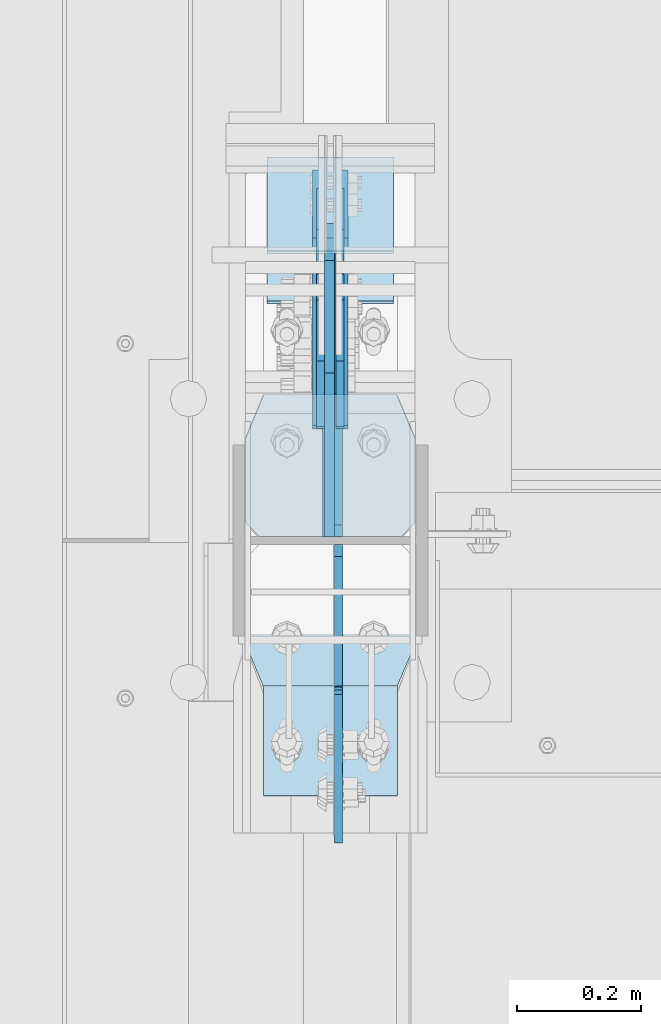
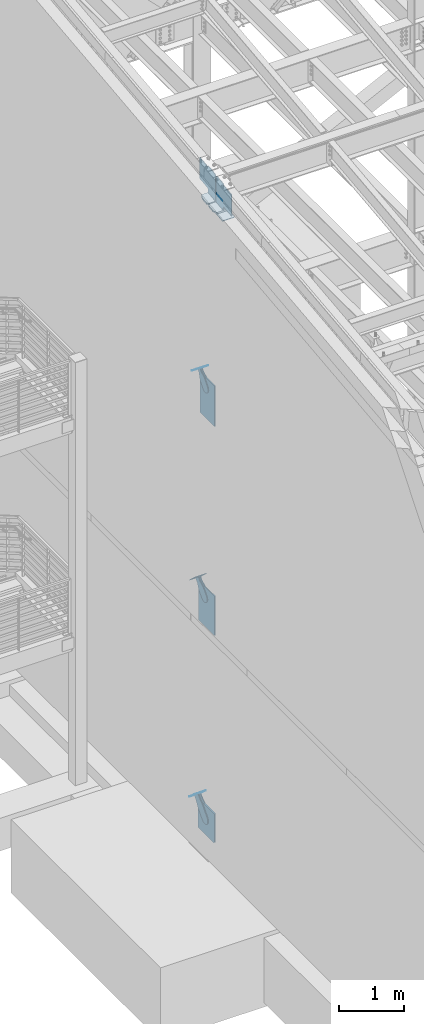
# One storey, part 1021 of 1179: 17 plates, 10 elements without a shape of their own.
"""IFC2X3 building model written with IfcOpenShell, lengths in millimetres."""

from ifc_helpers import new_model, si_unit, frame, origin_with_axes, place, context, subcontext, project, spatial, faceted_brep, material, type_object, element, aggregate, save


model = new_model("IFC2X3")

# Units and contexts
model_context = context("Model", 3, precision=1e-05, world=origin_with_axes())
body_context = subcontext(model_context, "Body", "Model", "MODEL_VIEW")
ifc_project = project(units=[si_unit("LENGTHUNIT", "METRE", prefix="MILLI"), si_unit("AREAUNIT", "SQUARE_METRE"), si_unit("VOLUMEUNIT", "CUBIC_METRE"), si_unit("MASSUNIT", "GRAM", prefix="KILO"), si_unit("TIMEUNIT", "SECOND"), si_unit("PLANEANGLEUNIT", "RADIAN"), si_unit("SOLIDANGLEUNIT", "STERADIAN"), si_unit("THERMODYNAMICTEMPERATUREUNIT", "DEGREE_CELSIUS"), si_unit("LUMINOUSINTENSITYUNIT", "LUMEN")], contexts=[model_context])

# Site, building, storey
site_placement = place(None, origin_with_axes())
site = spatial("IfcSite", under=ifc_project, at=site_placement, CompositionType="ELEMENT")
building_placement = place(site_placement, origin_with_axes())
building = spatial("IfcBuilding", under=site, at=building_placement, Name="Undefined", CompositionType="ELEMENT")
storey_placement = place(building_placement, origin_with_axes())
storey = spatial("IfcBuildingStorey", under=building, at=storey_placement, Name="Undefined", CompositionType="ELEMENT", Elevation=0.0)

# Assembly, plate
assembly_1_placement = place(storey_placement, origin_with_axes())
assembly_1 = element("IfcElementAssembly", 1, at=assembly_1_placement, inside=storey, AssemblyPlace="NOTDEFINED", PredefinedType="RIGID_FRAME")
ifc_material_1 = material(Name="STEEL/A36")
plate_type_1 = type_object("IfcPlateType", PredefinedType="NOTDEFINED")
plate_1_placement = place(assembly_1_placement, frame((415.925000000002, 27510.5287357584, 8311.01073836004), z_axis=(0.0, -0.784152810390106, 0.620567780308725), x_axis=(0.0, 0.620567780308726, 0.784152810390106)))
plate_1 = element("IfcPlate", 2, at=plate_1_placement, type_object=plate_type_1, material=ifc_material_1, context=body_context, shape_type="Brep", body=[
    faceted_brep([(0.0, -6.34999999999854, 0.0), (-101.600000000211, -6.34999999999854, -44.6881937825565), (-101.600000000211, 6.34999999999854, -44.6881937825565), (0.0, 6.34999999999854, 0.0), (-246.684985848258, -6.34999999999854, -44.6881937827675), (-246.684985848258, 6.34999999999854, -44.6881937827675), (-281.313054102191, -6.34999999999854, -37.800242748639), (-281.313054102191, 6.34999999999854, -37.800242748639), (-310.669312868691, -6.34999999999854, -18.1850177516608), (-310.669312868691, 6.34999999999854, -18.1850177516608), (-330.284537865713, -6.34999999999854, 11.1712410148393), (-330.284537865713, 6.34999999999854, 11.1712410148393), (-337.172488899912, -6.34999999999854, 45.7993031647638), (-337.172488899912, 6.34999999999854, 45.7993031647638), (-330.284537865768, -6.34999999999854, 80.4273714187839), (-330.284537865768, 6.34999999999854, 80.4273714187839), (-310.669312868773, -6.34999999999854, 109.783630185371), (-310.669312868773, 6.34999999999854, 109.783630185371), (-281.313054102271, -6.34999999999854, 129.398855182466), (-281.313054102271, 6.34999999999854, 129.398855182466), (-246.684988899762, -6.34999999999854, 136.286806216707), (-246.684988899762, 6.34999999999854, 136.286806216707), (-101.600000000377, -6.34999999999854, 136.286806216911), (-101.600000000377, 6.34999999999854, 136.286806216911), (-8.18545231595635e-11, -6.34999999999854, 91.5986124346418), (-8.18545231595635e-11, 6.34999999999854, 91.5986124346418), (67.3100000000013, -6.35000000000002, 91.5986124352912), (67.3100000000013, 6.35000000000002, 91.5986124352912), (67.309999999783, -6.35000000000002, -1.09139364212751e-11), (67.309999999783, 6.35000000000002, -1.09139364212751e-11)], [[[0, 1, 2, 3]], [[1, 4, 5, 2]], [[4, 6, 7, 5]], [[6, 8, 9, 7]], [[8, 10, 11, 9]], [[10, 12, 13, 11]], [[12, 14, 15, 13]], [[14, 16, 17, 15]], [[16, 18, 19, 17]], [[18, 20, 21, 19]], [[20, 22, 23, 21]], [[22, 24, 25, 23]], [[24, 26, 27, 25]], [[26, 28, 29, 27]], [[28, 0, 3, 29]], [[5, 7, 9, 11, 13, 15, 17, 19, 21, 23, 25, 27, 29, 3, 2]], [[28, 26, 24, 22, 20, 18, 16, 14, 12, 10, 8, 6, 4, 1, 0]]]),
])
aggregate(assembly_1, [plate_1])

assembly_2_placement = place(storey_placement, origin_with_axes())
assembly_2 = element("IfcElementAssembly", 3, at=assembly_2_placement, inside=storey, AssemblyPlace="NOTDEFINED", PredefinedType="RIGID_FRAME")
plate_2_placement = place(assembly_2_placement, frame((447.675000000002, 27510.5287357584, 8311.01073836004), z_axis=(0.0, -0.784152810390106, 0.620567780308725), x_axis=(0.0, 0.620567780308726, 0.784152810390106)))
plate_2 = element("IfcPlate", 4, at=plate_2_placement, type_object=plate_type_1, material=ifc_material_1, context=body_context, shape_type="Brep", body=[
    faceted_brep([(0.0, -6.34999999999854, 0.0), (-101.600000000211, -6.34999999999854, -44.6881937825565), (-101.600000000211, 6.34999999999854, -44.6881937825565), (0.0, 6.34999999999854, 0.0), (-246.684985848258, -6.34999999999854, -44.6881937827675), (-246.684985848258, 6.34999999999854, -44.6881937827675), (-281.313054102191, -6.34999999999854, -37.800242748639), (-281.313054102191, 6.34999999999854, -37.800242748639), (-310.669312868691, -6.34999999999854, -18.1850177516608), (-310.669312868691, 6.34999999999854, -18.1850177516608), (-330.284537865713, -6.34999999999854, 11.1712410148393), (-330.284537865713, 6.34999999999854, 11.1712410148393), (-337.172488899912, -6.34999999999854, 45.7993031647638), (-337.172488899912, 6.34999999999854, 45.7993031647638), (-330.284537865768, -6.34999999999854, 80.4273714187839), (-330.284537865768, 6.34999999999854, 80.4273714187839), (-310.669312868773, -6.34999999999854, 109.783630185371), (-310.669312868773, 6.34999999999854, 109.783630185371), (-281.313054102271, -6.34999999999854, 129.398855182466), (-281.313054102271, 6.34999999999854, 129.398855182466), (-246.684988899762, -6.34999999999854, 136.286806216707), (-246.684988899762, 6.34999999999854, 136.286806216707), (-101.600000000377, -6.34999999999854, 136.286806216911), (-101.600000000377, 6.34999999999854, 136.286806216911), (-8.18545231595635e-11, -6.34999999999854, 91.5986124346418), (-8.18545231595635e-11, 6.34999999999854, 91.5986124346418), (67.3100000000013, -6.35000000000002, 91.5986124352912), (67.3100000000013, 6.35000000000002, 91.5986124352912), (67.309999999783, -6.35000000000002, -1.09139364212751e-11), (67.309999999783, 6.35000000000002, -1.09139364212751e-11)], [[[0, 1, 2, 3]], [[1, 4, 5, 2]], [[4, 6, 7, 5]], [[6, 8, 9, 7]], [[8, 10, 11, 9]], [[10, 12, 13, 11]], [[12, 14, 15, 13]], [[14, 16, 17, 15]], [[16, 18, 19, 17]], [[18, 20, 21, 19]], [[20, 22, 23, 21]], [[22, 24, 25, 23]], [[24, 26, 27, 25]], [[26, 28, 29, 27]], [[28, 0, 3, 29]], [[5, 7, 9, 11, 13, 15, 17, 19, 21, 23, 25, 27, 29, 3, 2]], [[28, 26, 24, 22, 20, 18, 16, 14, 12, 10, 8, 6, 4, 1, 0]]]),
])
aggregate(assembly_2, [plate_2])

assembly_3_placement = place(storey_placement, origin_with_axes())
assembly_3 = element("IfcElementAssembly", 5, at=assembly_3_placement, inside=storey, Name="Plate", AssemblyPlace="NOTDEFINED", PredefinedType="RIGID_FRAME")
plate_type_2 = type_object("IfcPlateType", PredefinedType="NOTDEFINED")
plate_3_placement = place(assembly_3_placement, frame((533.400000000002, 27594.0851211982, 8326.67426617516), z_axis=(0.0, -0.784152810390106, 0.620567780308725), x_axis=(-1.0, 0.0, 0.0)))
plate_3 = element("IfcPlate", 6, at=plate_3_placement, type_object=plate_type_2, material=ifc_material_1, Name="Plate", context=body_context, shape_type="Brep", body=[
    faceted_brep([(0.0, -3.17500000000109, 0.0), (0.0, -3.17500000000291, 203.200000000368), (0.0, 3.17499999998836, 203.200000000361), (0.0, 3.17500000000109, 7.27595761418343e-12), (203.199999999997, -3.17500000000291, 203.200000000368), (203.199999999997, 3.17499999998836, 203.200000000361), (203.199999999997, -3.17499999999927, 3.63797880709171e-12), (203.199999999997, 3.17499999999382, -3.63797880709171e-12)], [[[0, 1, 2, 3]], [[1, 4, 5, 2]], [[4, 6, 7, 5]], [[6, 0, 3, 7]], [[5, 7, 3, 2]], [[6, 4, 1, 0]]]),
])
aggregate(assembly_3, [plate_3])

assembly_4_placement = place(storey_placement, origin_with_axes())
assembly_4 = element("IfcElementAssembly", 7, at=assembly_4_placement, inside=storey, Name="Plate", AssemblyPlace="NOTDEFINED", PredefinedType="RIGID_FRAME")
plate_4_placement = place(assembly_4_placement, frame((533.400000000002, 27649.6818635743, 4382.10915289887), z_axis=(0.0, -0.729241792887682, 0.684256097894611), x_axis=(-1.0, 0.0, 0.0)))
plate_4 = element("IfcPlate", 8, at=plate_4_placement, type_object=plate_type_2, material=ifc_material_1, Name="Plate", context=body_context, shape_type="Brep", body=[
    faceted_brep([(0.0, -3.17500000000109, 0.0), (0.0, -3.17500000000291, 203.200000000368), (0.0, 3.17499999998836, 203.200000000361), (0.0, 3.17500000000109, 7.27595761418343e-12), (203.199999999997, -3.17500000000291, 203.200000000368), (203.199999999997, 3.17499999998836, 203.200000000361), (203.199999999997, -3.17499999999927, 3.63797880709171e-12), (203.199999999997, 3.17499999999382, -3.63797880709171e-12)], [[[0, 1, 2, 3]], [[1, 4, 5, 2]], [[4, 6, 7, 5]], [[6, 0, 3, 7]], [[5, 7, 3, 2]], [[6, 4, 1, 0]]]),
])
aggregate(assembly_4, [plate_4])

assembly_5_placement = place(storey_placement, origin_with_axes())
assembly_5 = element("IfcElementAssembly", 9, at=assembly_5_placement, inside=storey, Name="Plate", AssemblyPlace="NOTDEFINED", PredefinedType="RIGID_FRAME")
plate_5_placement = place(assembly_5_placement, frame((533.400000000002, 27666.7905367789, 320.900120380222), z_axis=(0.0, -0.74575357167811, 0.666221892712438), x_axis=(-1.0, 0.0, 0.0)))
plate_5 = element("IfcPlate", 10, at=plate_5_placement, type_object=plate_type_2, material=ifc_material_1, Name="Plate", context=body_context, shape_type="Brep", body=[
    faceted_brep([(0.0, -3.17500000000109, 0.0), (0.0, -3.17500000000291, 203.200000000368), (0.0, 3.17499999998836, 203.200000000361), (0.0, 3.17500000000109, 7.27595761418343e-12), (203.199999999997, -3.17500000000291, 203.200000000368), (203.199999999997, 3.17499999998836, 203.200000000361), (203.199999999997, -3.17499999999927, 3.63797880709171e-12), (203.199999999997, 3.17499999999382, -3.63797880709171e-12)], [[[0, 1, 2, 3]], [[1, 4, 5, 2]], [[4, 6, 7, 5]], [[6, 0, 3, 7]], [[5, 7, 3, 2]], [[6, 4, 1, 0]]]),
])
aggregate(assembly_5, [plate_5])

# Assembly, plates
assembly_6_placement = place(storey_placement, origin_with_axes())
assembly_6 = element("IfcElementAssembly", 11, at=assembly_6_placement, inside=storey, Name="COLUMN", AssemblyPlace="NOTDEFINED", PredefinedType="RIGID_FRAME")
ifc_material_2 = material(Name="STEEL/A572-GR.50")
plate_type_3 = type_object("IfcPlateType", PredefinedType="NOTDEFINED")
plate_6_placement = place(assembly_6_placement, frame((323.850003041494, 26640.7392708403, 11698.0872863544), z_axis=(1.0, 0.0, 0.0), x_axis=(0.0, 0.993676146336441, 0.112284087038017)))
plate_6 = element("IfcPlate", 12, at=plate_6_placement, type_object=plate_type_3, material=ifc_material_2, Name="PLATE", context=body_context, shape_type="Brep", body=[
    faceted_brep([(0.0, -6.34999999999854, 0.0), (0.0, -6.350000000004, 215.899993896484), (0.0, 6.35000000000582, 215.899993896484), (0.0, 6.34999999999854, 0.0), (330.200000001782, -6.34999999994034, 215.899993896483), (330.200000001782, 6.35000000006767, 215.899993896483), (330.200000001782, -6.34999999994034, -1.47792889038101e-12), (330.200000001782, 6.35000000006767, -1.47792889038101e-12)], [[[0, 1, 2, 3]], [[1, 4, 5, 2]], [[4, 6, 7, 5]], [[6, 0, 3, 7]], [[5, 7, 3, 2]], [[6, 4, 1, 0]]]),
])
plate_type_4 = type_object("IfcPlateType", PredefinedType="NOTDEFINED")
plate_7_placement = place(assembly_6_placement, frame((295.27500000006, 26814.3139131712, 11738.3789032818), z_axis=(1.0, 0.0, 0.0), x_axis=(0.0, 0.993676146336441, 0.112284087038017)))
plate_7 = element("IfcPlate", 13, at=plate_7_placement, type_object=plate_type_4, material=ifc_material_2, Name="PLATE", context=body_context, shape_type="Brep", body=[
    faceted_brep([(207.962499617965, -14.2875000000749, 8.87325768417213e-11), (71.43750000002, -14.287499999984, 2.90469870378729e-11), (71.4375000000155, 14.2874999999949, 2.90469870378729e-11), (207.962499617975, 14.2874999999094, 8.87325768417213e-11), (230.187499999511, -14.287500000084, 22.225000381568), (230.187499999523, 14.2874999999003, 22.225000381568), (230.187500000431, -14.2875000000822, 250.824999623284), (230.187500000442, 14.2874999998985, 250.824999623284), (207.962499619063, -14.2875000000731, 273.050000004745), (207.962499619074, 14.2874999999112, 273.050000004745), (71.4375000016116, -14.2874999999858, 273.049999999798), (71.4375000016071, 14.2874999999967, 273.049999999798), (4.20737223302058, 14.2874999999931, 244.663945699182), (0.978435120117865, -14.2874999999894, 243.300616678719), (0.978435120117865, -14.2874999999894, 29.7493833255772), (4.20737223302058, 14.2874999999931, 28.3860543051127)], [[[0, 1, 2, 3]], [[4, 0, 3, 5]], [[6, 4, 5, 7]], [[8, 6, 7, 9]], [[10, 8, 9, 11]], [[10, 11, 12, 13]], [[1, 0, 4, 6, 8, 10, 13, 14]], [[2, 1, 14, 15]], [[11, 9, 7, 5, 3, 2, 15, 12]], [[14, 13, 12, 15]]]),
])
plate_type_5 = type_object("IfcPlateType", PredefinedType="NOTDEFINED")
plate_8_placement = place(assembly_6_placement, frame((568.325000000001, 27289.2635477105, 11792.0475823145), z_axis=(-1.0, 0.0, 0.0), x_axis=(0.0, -0.993676146336441, -0.112284087038017)))
plate_8 = element("IfcPlate", 14, at=plate_8_placement, type_object=plate_type_5, material=ifc_material_2, Name="PLATE", context=body_context, shape_type="Brep", body=[
    faceted_brep([(209.549999618157, -14.287499999904, 0.0), (73.0250015258425, -14.2874999999603, 0.0), (73.0250015258298, 14.2875000000258, 0.0), (209.549999618144, 14.2875000000804, 0.0), (231.774999999612, -14.2874999998949, 22.2250003814697), (231.774999999603, 14.2875000000895, 22.2250003814697), (231.774999999612, -14.2874999998949, 250.824999618533), (231.774999999603, 14.2875000000895, 250.824999618533), (209.549999618157, -14.287499999904, 273.050000000002), (209.549999618144, 14.2875000000804, 273.050000000002), (73.0250015258425, -14.2874999999603, 273.049999999998), (73.0250015258298, 14.2875000000258, 273.049999999998), (4.15974163581814, -14.2874999999876, 244.605653758279), (4.15974163581814, -14.2874999999876, 28.4443462417166), (0.930804522917242, 14.2874999999949, 29.7780376469105), (0.930804522917242, 14.2874999999949, 243.271962353085)], [[[0, 1, 2, 3]], [[4, 0, 3, 5]], [[6, 4, 5, 7]], [[8, 6, 7, 9]], [[10, 8, 9, 11]], [[1, 0, 4, 6, 8, 10, 12, 13]], [[2, 1, 13, 14]], [[11, 9, 7, 5, 3, 2, 14, 15]], [[10, 11, 15, 12]], [[14, 13, 12, 15]]]),
])
plate_type_6 = type_object("IfcPlateType", PredefinedType="NOTDEFINED")
plate_9_placement = place(assembly_6_placement, frame((445.293750000002, 27057.35, 11799.2397941051), z_axis=(0.0, 0.663574933899741, 0.748109822886957), x_axis=(0.0, 0.748109822886957, -0.663574933899741)))
plate_9 = element("IfcPlate", 15, at=plate_9_placement, type_object=plate_type_6, material=ifc_material_2, Name="PLATE", context=body_context, shape_type="Brep", body=[
    faceted_brep([(-303.238548430167, -6.35000000000002, 370.417244034568), (-303.347407870391, 6.35000000000002, 370.51520492656), (-303.447548924116, 6.35000000000002, 342.10495528072), (-303.447548924116, -6.35000000000002, 342.10495528072), (25.4641550948563, -6.35000000000002, 0.0), (0.0, -6.34999999999854, 0.0), (0.0, 6.34999999999854, 0.0), (25.4641550948563, 6.35000000000002, 0.0), (167.045917247172, -6.35000000000002, 157.353263970723), (167.045917247172, 6.35000000000002, 157.353263970723), (131.563526715495, -6.35000000000002, 197.355899250204), (131.563526715495, 6.35000000000002, 197.355899250204), (126.802866418006, -6.35000000000002, 205.238730036501), (126.802866418006, 6.35000000000002, 205.238730036501), (125.165683086001, -6.35000000000002, 214.300878700633), (125.165683086001, 6.35000000000002, 214.300878700633), (126.867175912115, -6.35000000000002, 223.351173161929), (126.867175912115, 6.35000000000002, 223.351173161929), (131.683692556814, -6.35000000000002, 231.199999512715), (131.683692556814, 6.35000000000002, 231.199999512715), (286.794657668127, -6.35000000000002, 403.589566389341), (286.794657668127, 6.35000000000002, 403.589566389341), (23.8827060644498, -6.35000000000002, 699.99493122035), (23.8827060644498, 6.35000000000002, 699.99493122035), (-127.388721232707, -6.35000000000002, 531.872607863961), (-127.388721232707, 6.35000000000002, 531.872607863961), (-134.060951024564, -6.35000000000002, 526.588932486246), (-134.060951024564, 6.35000000000002, 526.588932486246), (-142.104023886786, -6.35000000000002, 523.805974558898), (-142.104023886786, 6.35000000000002, 523.805974558898), (-150.614897093323, -6.35000000000002, 523.836193008534), (-150.614897093323, 6.35000000000002, 523.836193008534), (-158.638005243585, -6.35000000000002, 526.676195033468), (-158.638005243585, 6.35000000000002, 526.676195033468), (-161.065417892858, 6.35000000000002, 528.626645817876), (-161.065417892858, -6.35000000000002, 528.626645817876)], [[[0, 1, 2, 3]], [[4, 5, 6, 7]], [[8, 4, 7, 9]], [[10, 8, 9, 11]], [[12, 10, 11, 13]], [[14, 12, 13, 15]], [[16, 14, 15, 17]], [[18, 16, 17, 19]], [[20, 18, 19, 21]], [[22, 20, 21, 23]], [[24, 22, 23, 25]], [[26, 24, 25, 27]], [[28, 26, 27, 29]], [[30, 28, 29, 31]], [[32, 30, 31, 33]], [[32, 33, 34, 35]], [[5, 4, 8, 10, 12, 14, 16, 18, 20, 22, 24, 26, 28, 30, 32, 35, 0, 3]], [[6, 5, 3, 2]], [[34, 33, 31, 29, 27, 25, 23, 21, 19, 17, 15, 13, 11, 9, 7, 6, 2, 1]], [[35, 34, 1, 0]]]),
])
plate_type_7 = type_object("IfcPlateType", PredefinedType="NOTDEFINED")
plate_10_placement = place(assembly_6_placement, frame((445.293750000002, 27044.6499999809, 11797.4396066722), z_axis=(0.0, -0.743858433013958, 0.668337214012522), x_axis=(0.0, -0.668337214012522, -0.743858433013957)))
plate_10 = element("IfcPlate", 16, at=plate_10_placement, type_object=plate_type_7, material=ifc_material_2, Name="PLATE", context=body_context, shape_type="Brep", body=[
    faceted_brep([(-340.307722614409, -6.35000000000002, 331.196209351952), (-340.360268739241, 6.35000000000002, 331.25535654785), (-340.432897072962, 6.35000000000002, 305.869993370221), (-340.432897072962, -6.35000000000002, 305.869993370221), (28.5035613092805, -6.35000000000002, -1.04591890703887e-11), (0.0, -6.34999999999854, 0.0), (0.0, 6.34999999999854, 0.0), (28.5035613092805, 6.35000000000002, -1.04591890703887e-11), (185.535041792471, -6.35000000000002, 139.488379402524), (185.535041792471, 6.35000000000002, 139.488379402524), (150.391206739107, -6.35000000000002, 171.064189752232), (150.391206739107, 6.35000000000002, 171.064189752232), (145.102749755571, -6.35000000000002, 177.732630246504), (145.102749755571, 6.35000000000002, 177.732630246504), (142.314026896069, -6.35000000000002, 185.773706089029), (142.314026896069, 6.35000000000002, 185.773706089029), (142.338144349787, -6.35000000000002, 194.28459877081), (142.338144349787, 6.35000000000002, 194.28459877081), (145.172394309466, -6.35000000000002, 202.30974070466), (145.172394309466, 6.35000000000002, 202.30974070466), (150.498558992693, -6.35000000000002, 208.948102374491), (150.498558992693, 6.35000000000002, 208.948102374491), (319.572465694362, -6.35000000000002, 359.133576332748), (319.572465694362, 6.35000000000002, 359.133576332748), (24.8516291671876, -6.35000000000002, 623.932487042394), (24.8516291671876, 6.35000000000002, 623.932487042394), (-148.513946545472, -6.35000000000002, 469.934796538949), (-148.513946545472, 6.35000000000002, 469.934796538949), (-156.393362644572, -6.35000000000002, 465.168486686387), (-156.393362644572, 6.35000000000002, 465.168486686387), (-165.454335371476, -6.35000000000002, 463.524807607098), (-165.454335371476, 6.35000000000002, 463.524807607098), (-174.505847216309, -6.35000000000002, 465.219812325748), (-174.505847216309, 6.35000000000002, 465.219812325748), (-182.358124252696, -6.35000000000002, 470.030701330617), (-182.358124252696, 6.35000000000002, 470.030701330617), (-183.249688243475, 6.35000000000002, 470.831748115088), (-183.249688243475, -6.35000000000002, 470.831748115088)], [[[0, 1, 2, 3]], [[4, 5, 6, 7]], [[8, 4, 7, 9]], [[10, 8, 9, 11]], [[12, 10, 11, 13]], [[14, 12, 13, 15]], [[16, 14, 15, 17]], [[18, 16, 17, 19]], [[20, 18, 19, 21]], [[22, 20, 21, 23]], [[24, 22, 23, 25]], [[26, 24, 25, 27]], [[28, 26, 27, 29]], [[30, 28, 29, 31]], [[32, 30, 31, 33]], [[34, 32, 33, 35]], [[34, 35, 36, 37]], [[5, 4, 8, 10, 12, 14, 16, 18, 20, 22, 24, 26, 28, 30, 32, 34, 37, 0, 3]], [[6, 5, 3, 2]], [[36, 35, 33, 31, 29, 27, 25, 23, 21, 19, 17, 15, 13, 11, 9, 7, 6, 2, 1]], [[37, 36, 1, 0]]]),
])

# Assembly, plate
assembly_7_placement = place(storey_placement, origin_with_axes())
assembly_7 = element("IfcElementAssembly", 17, at=assembly_7_placement, inside=storey, AssemblyPlace="NOTDEFINED", PredefinedType="RIGID_FRAME")
plate_type_8 = type_object("IfcPlateType", PredefinedType="NOTDEFINED")
plate_11_placement = place(assembly_7_placement, frame((415.925000000002, 27562.1830396846, 4355.36439363649), z_axis=(0.0, -0.729241792887682, 0.684256097894611), x_axis=(0.0, 0.684256097894612, 0.729241792887681)))
plate_11 = element("IfcPlate", 18, at=plate_11_placement, type_object=plate_type_8, material=ifc_material_1, context=body_context, shape_type="Brep", body=[
    faceted_brep([(0.0, -6.34999999999854, 0.0), (-101.599999999963, -6.34999999999854, -37.5700345970108), (-101.599999999963, 6.34999999999854, -37.5700345970108), (0.0, 6.34999999999854, 0.0), (-245.369242323884, -6.34999999999854, -37.5700345970945), (-245.369242323884, 6.34999999999854, -37.5700345970945), (-281.212328723803, -6.34999999999854, -30.4404014271258), (-281.212328723803, 6.34999999999854, -30.4404014271258), (-311.598630137756, -6.34999999999854, -10.1369239370142), (-311.598630137756, 6.34999999999854, -10.1369239370142), (-331.902107627997, -6.34999999999854, 20.24937747687), (-331.902107627997, 6.34999999999854, 20.24937747687), (-339.031740798124, -6.34999999999854, 56.0924669287269), (-339.031740798124, 6.34999999999854, 56.0924669287269), (-331.902107628228, -6.34999999999854, 91.9355533287926), (-331.902107628228, 6.34999999999854, 91.9355533287926), (-311.598630138099, -6.34999999999854, 122.321854742866), (-311.598630138099, 6.34999999999854, 122.321854742866), (-281.212328724136, -6.34999999999854, 142.625332233139), (-281.212328724136, 6.34999999999854, 142.625332233139), (-245.36924079839, -6.34999999999854, 149.754965403199), (-245.36924079839, 6.34999999999854, 149.754965403199), (-101.600000000685, -6.34999999999854, 149.75496540329), (-101.600000000685, 6.34999999999854, 149.75496540329), (-4.35647962149233e-10, -6.34999999999854, 112.184930806416), (-4.35647962149233e-10, 6.34999999999854, 112.184930806416), (82.5499999996491, -6.34999999999854, 112.184930806461), (82.5499999996491, 6.34999999999854, 112.184930806461), (82.550000000203, -6.34999999999854, 1.2732925824821e-10), (82.550000000203, 6.34999999999854, 1.2732925824821e-10)], [[[0, 1, 2, 3]], [[1, 4, 5, 2]], [[4, 6, 7, 5]], [[6, 8, 9, 7]], [[8, 10, 11, 9]], [[10, 12, 13, 11]], [[12, 14, 15, 13]], [[14, 16, 17, 15]], [[16, 18, 19, 17]], [[18, 20, 21, 19]], [[20, 22, 23, 21]], [[22, 24, 25, 23]], [[24, 26, 27, 25]], [[26, 28, 29, 27]], [[28, 0, 3, 29]], [[5, 7, 9, 11, 13, 15, 17, 19, 21, 23, 25, 27, 29, 3, 2]], [[28, 26, 24, 22, 20, 18, 16, 14, 12, 10, 8, 6, 4, 1, 0]]]),
])
aggregate(assembly_7, [plate_11])

assembly_8_placement = place(storey_placement, origin_with_axes())
assembly_8 = element("IfcElementAssembly", 19, at=assembly_8_placement, inside=storey, AssemblyPlace="NOTDEFINED", PredefinedType="RIGID_FRAME")
plate_12_placement = place(assembly_8_placement, frame((447.675000000002, 27562.1830396846, 4355.36439363649), z_axis=(0.0, -0.729241792887682, 0.684256097894611), x_axis=(0.0, 0.684256097894612, 0.729241792887681)))
plate_12 = element("IfcPlate", 20, at=plate_12_placement, type_object=plate_type_8, material=ifc_material_1, context=body_context, shape_type="Brep", body=[
    faceted_brep([(0.0, -6.34999999999854, 0.0), (-101.599999999963, -6.34999999999854, -37.5700345970108), (-101.599999999963, 6.34999999999854, -37.5700345970108), (0.0, 6.34999999999854, 0.0), (-245.369242323884, -6.34999999999854, -37.5700345970945), (-245.369242323884, 6.34999999999854, -37.5700345970945), (-281.212328723803, -6.34999999999854, -30.4404014271258), (-281.212328723803, 6.34999999999854, -30.4404014271258), (-311.598630137756, -6.34999999999854, -10.1369239370142), (-311.598630137756, 6.34999999999854, -10.1369239370142), (-331.902107627997, -6.34999999999854, 20.24937747687), (-331.902107627997, 6.34999999999854, 20.24937747687), (-339.031740798124, -6.34999999999854, 56.0924669287269), (-339.031740798124, 6.34999999999854, 56.0924669287269), (-331.902107628228, -6.34999999999854, 91.9355533287926), (-331.902107628228, 6.34999999999854, 91.9355533287926), (-311.598630138099, -6.34999999999854, 122.321854742866), (-311.598630138099, 6.34999999999854, 122.321854742866), (-281.212328724136, -6.34999999999854, 142.625332233139), (-281.212328724136, 6.34999999999854, 142.625332233139), (-245.36924079839, -6.34999999999854, 149.754965403199), (-245.36924079839, 6.34999999999854, 149.754965403199), (-101.600000000685, -6.34999999999854, 149.75496540329), (-101.600000000685, 6.34999999999854, 149.75496540329), (-4.35647962149233e-10, -6.34999999999854, 112.184930806416), (-4.35647962149233e-10, 6.34999999999854, 112.184930806416), (82.5499999996491, -6.34999999999854, 112.184930806461), (82.5499999996491, 6.34999999999854, 112.184930806461), (82.550000000203, -6.34999999999854, 1.2732925824821e-10), (82.550000000203, 6.34999999999854, 1.2732925824821e-10)], [[[0, 1, 2, 3]], [[1, 4, 5, 2]], [[4, 6, 7, 5]], [[6, 8, 9, 7]], [[8, 10, 11, 9]], [[10, 12, 13, 11]], [[12, 14, 15, 13]], [[14, 16, 17, 15]], [[16, 18, 19, 17]], [[18, 20, 21, 19]], [[20, 22, 23, 21]], [[22, 24, 25, 23]], [[24, 26, 27, 25]], [[26, 28, 29, 27]], [[28, 0, 3, 29]], [[5, 7, 9, 11, 13, 15, 17, 19, 21, 23, 25, 27, 29, 3, 2]], [[28, 26, 24, 22, 20, 18, 16, 14, 12, 10, 8, 6, 4, 1, 0]]]),
])
aggregate(assembly_8, [plate_12])

# Plate
plate_type_9 = type_object("IfcPlateType", PredefinedType="NOTDEFINED")
plate_13_placement = place(assembly_6_placement, frame((431.800000000002, 27057.35, 7575.55), z_axis=(0.0, 0.0, 1.0), x_axis=(0.0, 1.0, 0.0)))
plate_13 = element("IfcPlate", 21, at=plate_13_placement, type_object=plate_type_9, material=ifc_material_2, Name="PLATE", context=body_context, shape_type="Brep", body=[
    faceted_brep([(0.0, -9.52499999999964, 0.0), (0.0, -9.52499999999998, 756.128435263005), (0.0, 9.52499999999998, 756.128435263005), (0.0, 9.52499999999964, 0.0), (263.341885783306, -9.52499999999998, 756.128435263005), (263.341885783306, 9.52499999999998, 756.128435263005), (445.088903411473, -9.52499999999998, 612.296337981949), (445.088903411473, 9.52499999999998, 612.296337981949), (445.088903411473, -9.52499999999998, 0.0), (445.088903411473, 9.52499999999998, 0.0)], [[[0, 1, 2, 3]], [[1, 4, 5, 2]], [[4, 6, 7, 5]], [[6, 8, 9, 7]], [[8, 0, 3, 9]], [[5, 7, 9, 3, 2]], [[8, 6, 4, 1, 0]]]),
])

plate_type_10 = type_object("IfcPlateType", PredefinedType="NOTDEFINED")
plate_14_placement = place(assembly_6_placement, frame((431.800000000002, 27057.3499999352, 3663.95000006083), z_axis=(0.0, 0.0, 1.0), x_axis=(0.0, 1.0, 0.0)))
plate_14 = element("IfcPlate", 22, at=plate_14_placement, type_object=plate_type_10, material=ifc_material_2, Name="PLATE", context=body_context, shape_type="Brep", body=[
    faceted_brep([(0.0, -9.52499999999964, 0.0), (0.0, -9.52499999999998, 737.174280571875), (0.0, 9.52499999999998, 737.174280571875), (0.0, 9.52499999999964, 0.0), (307.582299199603, -9.52499999999998, 737.174280571875), (307.582299199603, 9.52499999999998, 737.174280571875), (481.233001130982, -9.52499999999998, 574.235797260721), (481.233001130982, 9.52499999999998, 574.235797260721), (481.233001130982, -9.52499999999998, 0.0), (481.233001130982, 9.52499999999998, 0.0)], [[[0, 1, 2, 3]], [[1, 4, 5, 2]], [[4, 6, 7, 5]], [[6, 8, 9, 7]], [[8, 0, 3, 9]], [[5, 7, 9, 3, 2]], [[8, 6, 4, 1, 0]]]),
])

plate_type_11 = type_object("IfcPlateType", PredefinedType="NOTDEFINED")
plate_15_placement = place(assembly_6_placement, frame((431.800000000001, 27057.35, -215.9), z_axis=(0.0, 0.0, 1.0), x_axis=(0.0, 1.0, 0.0)))
plate_15 = element("IfcPlate", 23, at=plate_15_placement, type_object=plate_type_11, material=ifc_material_2, Name="PLATE", context=body_context, shape_type="Brep", body=[
    faceted_brep([(0.0, -12.7000000000007, 19.0500000000029), (0.0, -12.7, 551.799398203347), (0.0, 12.7, 551.799398203347), (0.0, 12.7000000000007, 19.0500000000029), (324.819501230952, -12.7, 551.799398203347), (324.819501230952, 12.7, 551.799398203347), (504.769838076878, -12.7, 391.040055491836), (504.769838076878, 12.7, 391.040055491836), (504.769838076878, -12.7, 0.0), (504.769838076878, 12.7, 0.0), (19.0499992370605, -12.6999999999971, 0.0), (19.0499992370605, 12.6999999999971, 0.0)], [[[0, 1, 2, 3]], [[1, 4, 5, 2]], [[4, 6, 7, 5]], [[6, 8, 9, 7]], [[8, 10, 11, 9]], [[10, 0, 3, 11]], [[5, 7, 9, 11, 3, 2]], [[10, 8, 6, 4, 1, 0]]]),
])

aggregate(assembly_6, [plate_6, plate_8, plate_9, plate_7, plate_10, plate_13, plate_14, plate_15])

# Assembly, plate
assembly_9_placement = place(storey_placement, origin_with_axes())
assembly_9 = element("IfcElementAssembly", 24, at=assembly_9_placement, inside=storey, AssemblyPlace="NOTDEFINED", PredefinedType="RIGID_FRAME")
plate_type_12 = type_object("IfcPlateType", PredefinedType="NOTDEFINED")
plate_16_placement = place(assembly_9_placement, frame((411.162500000002, 27594.6102194491, 282.352678620126), z_axis=(0.0, -0.74575357167811, 0.666221892712438), x_axis=(0.0, 0.666221892712437, 0.74575357167811)))
plate_16 = element("IfcPlate", 25, at=plate_16_placement, type_object=plate_type_12, material=ifc_material_1, context=body_context, shape_type="Brep", body=[
    faceted_brep([(0.0, -7.9375, 0.0), (-101.600000000497, -7.9375, -21.7975798445477), (-101.600000000497, 7.9375, -21.7975798445477), (0.0, 7.9375, 0.0), (-320.921138851689, -7.9375, -21.7975798443877), (-320.921138851689, 7.9375, -21.7975798443877), (-357.371735784433, -7.9375, -14.5471053160727), (-357.371735784433, 7.9375, -14.5471053160727), (-388.273059759649, -7.9375, 6.10049924760824), (-388.273059759649, 7.9375, 6.10049924760824), (-408.920664323319, -7.9375, 37.0018232228431), (-408.920664323319, 7.9375, 37.0018232228431), (-416.171138851623, -7.9375, 73.4524201546446), (-416.171138851623, 7.9375, 73.4524201546446), (-408.920664323337, -7.9375, 109.903017087447), (-408.920664323337, 7.9375, 109.903017087447), (-388.273059759656, -7.9375, 140.804341062707), (-388.273059759656, 7.9375, 140.804341062707), (-357.3717357844, -7.9375, 161.451945626395), (-357.3717357844, 7.9375, 161.451945626395), (-320.921138851201, -7.9375, 168.702420154674), (-320.921138851201, 7.9375, 168.702420154674), (-101.600000000592, -7.9375, 168.702420154521), (-101.600000000592, 7.9375, 168.702420154521), (-8.00355337560177e-11, -7.9375, 146.904840309817), (-8.00355337560177e-11, 7.9375, 146.904840309817), (80.0100000003295, -7.9375, 146.904840309766), (80.0100000003295, 7.9375, 146.904840309766), (80.0100000004022, -7.9375, -5.82076609134674e-11), (80.0100000004022, 7.9375, -5.82076609134674e-11)], [[[0, 1, 2, 3]], [[1, 4, 5, 2]], [[4, 6, 7, 5]], [[6, 8, 9, 7]], [[8, 10, 11, 9]], [[10, 12, 13, 11]], [[12, 14, 15, 13]], [[14, 16, 17, 15]], [[16, 18, 19, 17]], [[18, 20, 21, 19]], [[20, 22, 23, 21]], [[22, 24, 25, 23]], [[24, 26, 27, 25]], [[26, 28, 29, 27]], [[28, 0, 3, 29]], [[5, 7, 9, 11, 13, 15, 17, 19, 21, 23, 25, 27, 29, 3, 2]], [[28, 26, 24, 22, 20, 18, 16, 14, 12, 10, 8, 6, 4, 1, 0]]]),
])
aggregate(assembly_9, [plate_16])

assembly_10_placement = place(storey_placement, origin_with_axes())
assembly_10 = element("IfcElementAssembly", 26, at=assembly_10_placement, inside=storey, AssemblyPlace="NOTDEFINED", PredefinedType="RIGID_FRAME")
plate_17_placement = place(assembly_10_placement, frame((452.437500000002, 27594.6102194491, 282.352678620126), z_axis=(0.0, -0.74575357167811, 0.666221892712438), x_axis=(0.0, 0.666221892712437, 0.74575357167811)))
plate_17 = element("IfcPlate", 27, at=plate_17_placement, type_object=plate_type_12, material=ifc_material_1, context=body_context, shape_type="Brep", body=[
    faceted_brep([(0.0, -7.9375, 0.0), (-101.600000000497, -7.9375, -21.7975798445477), (-101.600000000497, 7.9375, -21.7975798445477), (0.0, 7.9375, 0.0), (-320.921138851689, -7.9375, -21.7975798443877), (-320.921138851689, 7.9375, -21.7975798443877), (-357.371735784433, -7.9375, -14.5471053160727), (-357.371735784433, 7.9375, -14.5471053160727), (-388.273059759649, -7.9375, 6.10049924760824), (-388.273059759649, 7.9375, 6.10049924760824), (-408.920664323319, -7.9375, 37.0018232228431), (-408.920664323319, 7.9375, 37.0018232228431), (-416.171138851623, -7.9375, 73.4524201546446), (-416.171138851623, 7.9375, 73.4524201546446), (-408.920664323337, -7.9375, 109.903017087447), (-408.920664323337, 7.9375, 109.903017087447), (-388.273059759656, -7.9375, 140.804341062707), (-388.273059759656, 7.9375, 140.804341062707), (-357.3717357844, -7.9375, 161.451945626395), (-357.3717357844, 7.9375, 161.451945626395), (-320.921138851201, -7.9375, 168.702420154674), (-320.921138851201, 7.9375, 168.702420154674), (-101.600000000592, -7.9375, 168.702420154521), (-101.600000000592, 7.9375, 168.702420154521), (-8.00355337560177e-11, -7.9375, 146.904840309817), (-8.00355337560177e-11, 7.9375, 146.904840309817), (80.0100000003295, -7.9375, 146.904840309766), (80.0100000003295, 7.9375, 146.904840309766), (80.0100000004022, -7.9375, -5.82076609134674e-11), (80.0100000004022, 7.9375, -5.82076609134674e-11)], [[[0, 1, 2, 3]], [[1, 4, 5, 2]], [[4, 6, 7, 5]], [[6, 8, 9, 7]], [[8, 10, 11, 9]], [[10, 12, 13, 11]], [[12, 14, 15, 13]], [[14, 16, 17, 15]], [[16, 18, 19, 17]], [[18, 20, 21, 19]], [[20, 22, 23, 21]], [[22, 24, 25, 23]], [[24, 26, 27, 25]], [[26, 28, 29, 27]], [[28, 0, 3, 29]], [[5, 7, 9, 11, 13, 15, 17, 19, 21, 23, 25, 27, 29, 3, 2]], [[28, 26, 24, 22, 20, 18, 16, 14, 12, 10, 8, 6, 4, 1, 0]]]),
])
aggregate(assembly_10, [plate_17])

save(model, "model.ifc")
